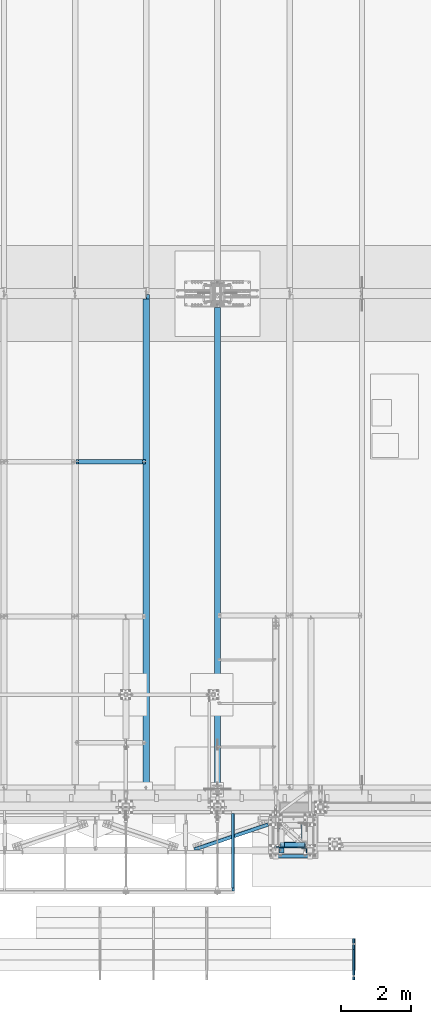
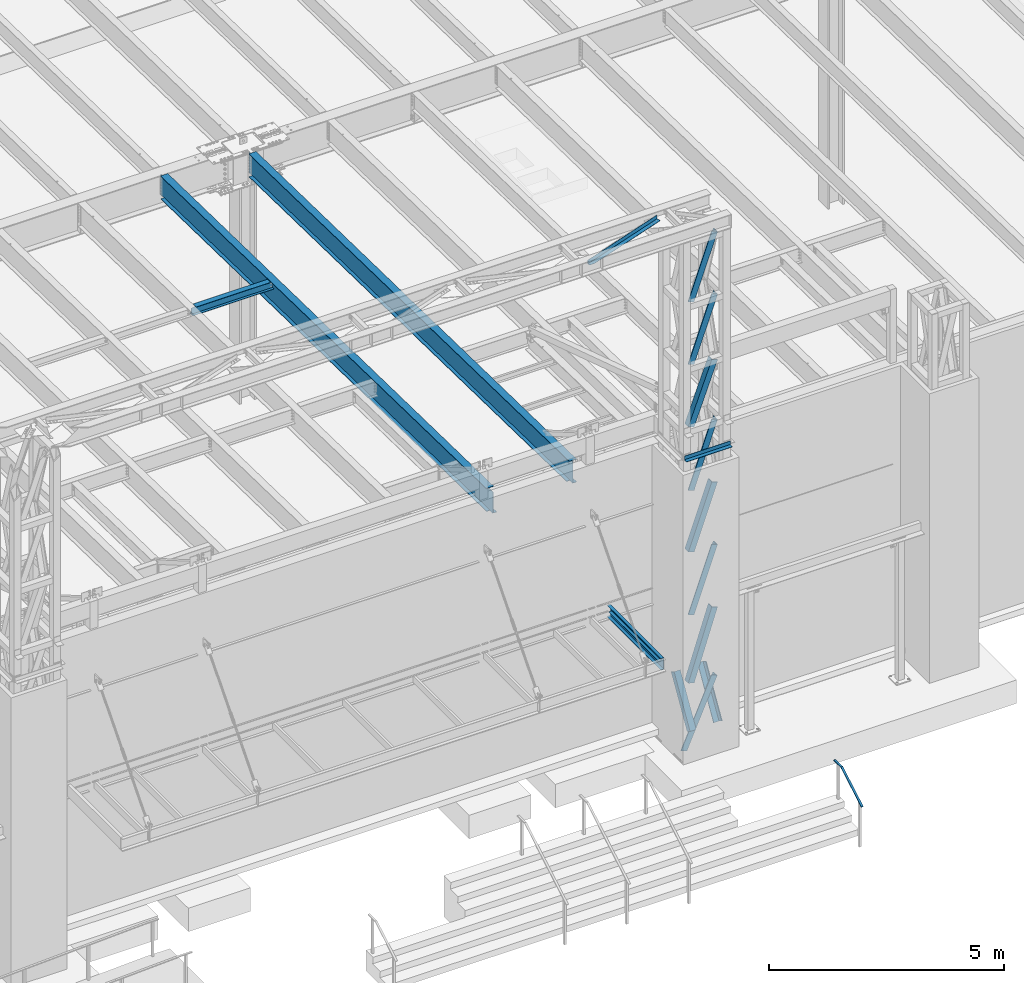
# One storey, part 1061 of 1763: 10 members, 8 beams, 7 elements without a shape of their own.
"""IFC2X3 building model written with IfcOpenShell, lengths in millimetres."""

from ifc_helpers import new_model, si_unit, frame, origin_with_axes, place, context, subcontext, project, spatial, faceted_brep, material, type_object, element, aggregate, save


model = new_model("IFC2X3")

# Units and contexts
model_context = context("Model", 3, precision=1e-05, world=origin_with_axes())
body_context = subcontext(model_context, "Body", "Model", "MODEL_VIEW")
ifc_project = project(units=[si_unit("LENGTHUNIT", "METRE", prefix="MILLI"), si_unit("AREAUNIT", "SQUARE_METRE"), si_unit("VOLUMEUNIT", "CUBIC_METRE"), si_unit("MASSUNIT", "GRAM", prefix="KILO"), si_unit("TIMEUNIT", "SECOND"), si_unit("PLANEANGLEUNIT", "RADIAN"), si_unit("SOLIDANGLEUNIT", "STERADIAN"), si_unit("THERMODYNAMICTEMPERATUREUNIT", "DEGREE_CELSIUS"), si_unit("LUMINOUSINTENSITYUNIT", "LUMEN")], contexts=[model_context])

# Site, building, storey
site_placement = place(None, origin_with_axes())
site = spatial("IfcSite", under=ifc_project, at=site_placement, CompositionType="ELEMENT")
building_placement = place(site_placement, origin_with_axes())
building = spatial("IfcBuilding", under=site, at=building_placement, Name="Undefined", CompositionType="ELEMENT")
storey_placement = place(building_placement, origin_with_axes())
storey = spatial("IfcBuildingStorey", under=building, at=storey_placement, Name="Undefined", CompositionType="ELEMENT", Elevation=0.0)

# Assembly, beam
assembly_1_placement = place(storey_placement, origin_with_axes())
assembly_1 = element("IfcElementAssembly", 1, at=assembly_1_placement, inside=storey, Name="BEAM", AssemblyPlace="NOTDEFINED", PredefinedType="RIGID_FRAME")
ifc_material_1 = material(Name="STEEL/A992")
beam_type_1 = type_object("IfcBeamType", Name="W8X18", PredefinedType="NOTDEFINED")
beam_1_placement = place(assembly_1_placement, frame((-53466.4372736983, -4344.55643304548, 11905.5938232069), z_axis=(0.0, 0.0, 1.0), x_axis=(1.0, 0.0, 0.0)))
beam_1 = element("IfcBeam", 2, at=beam_1_placement, type_object=beam_type_1, material=ifc_material_1, Name="BEAM", ObjectType="W8X18", context=body_context, shape_type="Brep", body=[
    faceted_brep([(87.3125001907247, -3.17500000000018, 64.8275016680727), (87.3125001907247, 3.17500000000018, 64.8275016680727), (17.4624999999905, 3.17500000000018, 64.8275016680727), (17.4624999999905, -3.17500000000018, 64.8275016680727), (92.1725797087711, -3.17500000000018, 65.7942315906603), (92.1725797087711, 3.17500000000018, 65.7942315906603), (96.2927561769247, -3.17500000000018, 68.5472454911378), (96.2927561769247, 3.17500000000018, 68.5472454911378), (97.1527139098253, -3.17500000000018, 69.8342631898486), (97.1527139098253, 3.17500000000018, 69.8342631898486), (17.4624999999905, -3.17500000000018, -95.25), (17.4624999999905, -66.6750000000002, -95.25), (2014.53750000001, -66.6750000000002, -95.25), (2014.53750000001, -3.17500000000018, -95.25), (17.4624999999905, -66.6750000000002, -103.1875), (2014.53750000001, -66.6750000000002, -103.1875), (17.4624999999905, 66.6750000000002, -103.1875), (2014.53750000001, 66.6750000000002, -103.1875), (17.4624999999905, 66.6750000000002, -95.25), (2014.53750000001, 66.6750000000002, -95.25), (17.4624999999905, 3.17500000000018, -95.25), (2014.53750000001, 3.17500000000018, -95.25), (2014.53750000001, 3.17500000000018, 64.8275016741045), (2014.53750000001, -3.17500000000018, 64.8275016741045), (1944.68749980927, 3.17500000000018, 64.8275016741045), (1944.68749980927, -3.17500000000018, 64.8275016741045), (1939.82742029122, 3.17500000000018, 65.794231596692), (1939.82742029122, -3.17500000000018, 65.794231596692), (1935.70724382307, 3.17500000000018, 68.5472454971696), (1935.70724382307, -3.17500000000018, 68.5472454971696), (1934.84728609776, 3.17500000000018, 69.8342631845208), (1934.84728609776, -3.17500000000018, 69.8342631845208), (1934.11974687481, 3.17500000000018, 70.3203893515383), (1934.11974687481, -3.17500000000018, 70.3203893515383), (1931.36673297434, 3.17500000000018, 74.440565819692), (1931.36673297434, -3.17500000000018, 74.440565819692), (1930.40000305175, 3.17500000000018, 79.3006453377384), (1930.40000305175, -3.17500000000018, 79.3006453377384), (101.599996948244, 3.17500000000018, 95.25), (101.599996948244, 66.6750000000002, 95.25), (1930.40000305175, 66.6750000000002, 95.25), (1930.40000305175, 3.17500000000018, 95.25), (101.599996948244, -66.6750000000002, 103.1875), (101.599996948244, -66.6750000000002, 95.25), (1930.40000305175, -66.6750000000002, 95.25), (1930.40000305175, -66.6750000000002, 103.1875), (101.599996948244, 66.6750000000002, 103.1875), (1930.40000305175, 66.6750000000002, 103.1875), (1930.40000305175, -3.17500000000018, 95.25), (101.599996948244, -3.17500000000018, 95.25), (101.599996948244, 3.17500000000018, 79.3006453379949), (101.599996948244, -3.17500000000018, 79.3006453379949), (100.633267025656, 3.17500000000018, 74.4405658199485), (100.633267025656, -3.17500000000018, 74.4405658199485), (97.8802531251786, 3.17500000000018, 70.3203893517948), (97.8802531251786, -3.17500000000018, 70.3203893517948)], [[[0, 1, 2, 3]], [[4, 5, 1, 0]], [[6, 7, 5, 4]], [[8, 9, 7, 6]], [[10, 11, 12, 13]], [[11, 14, 15, 12]], [[14, 16, 17, 15]], [[16, 18, 19, 17]], [[18, 20, 21, 19]], [[13, 12, 15, 17, 19, 21, 22, 23]], [[23, 22, 24, 25]], [[25, 24, 26, 27]], [[27, 26, 28, 29]], [[29, 28, 30, 31]], [[32, 33, 31, 30]], [[33, 32, 34, 35]], [[35, 34, 36, 37]], [[38, 39, 40, 41]], [[42, 43, 44, 45]], [[46, 42, 45, 47]], [[39, 46, 47, 40]], [[45, 44, 48, 37, 36, 41, 40, 47]], [[43, 49, 48, 44]], [[42, 46, 39, 38, 50, 51, 49, 43]], [[51, 50, 52, 53]], [[53, 52, 54, 55]], [[4, 0, 3, 10, 13, 23, 25, 27, 29, 31, 33, 35, 37, 48, 49, 51, 53, 55, 8, 6]], [[20, 18, 16, 14, 11, 10, 3, 2]], [[54, 52, 50, 38, 41, 36, 34, 32, 30, 28, 26, 24, 22, 21, 20, 2, 1, 5, 7, 9]], [[55, 54, 9, 8]]]),
])
aggregate(assembly_1, [beam_1])

# Assembly, members
assembly_2_placement = place(storey_placement, origin_with_axes())
assembly_2 = element("IfcElementAssembly", 3, at=assembly_2_placement, inside=storey, Name="FRAME", AssemblyPlace="NOTDEFINED", PredefinedType="RIGID_FRAME")
ifc_material_2 = material(Name="STEEL/A36")
member_type = type_object("IfcMemberType", Name="L6X6X7/8", PredefinedType="NOTDEFINED")
member_1_placement = place(assembly_2_placement, frame((-46925.9272043448, -15452.7272077239, 5676.9), z_axis=(-1.0, 0.0, 0.0), x_axis=(0.0, 0.513027731048337, 0.858372033080875)))
member_1 = element("IfcMember", 4, at=member_1_placement, type_object=member_type, material=ifc_material_2, Name="V. BRACE", ObjectType="L6X6X7/8", context=body_context, shape_type="Brep", body=[
    faceted_brep([(9.09494701772928e-13, 76.2000000000007, -76.2000000000844), (0.0, 76.2000000000007, 76.2000000000771), (1326.04215441225, 76.2000000009157, 76.1999999999971), (1326.04215441225, 76.2000000009157, -76.1999999999971), (0.0, 53.9750000000004, 76.2000000000771), (1326.04215441225, 53.9750000009208, 76.1999999999971), (1.81898940354586e-12, 53.9750000000004, -53.9750000000604), (1326.04215441225, 53.9750000009208, -53.9749999999985), (1.81898940354586e-12, -76.2000000000007, -53.9750000000604), (1326.04215441224, -76.199999999053, -53.9749999999985), (9.09494701772928e-13, -76.2000000000007, -76.2000000000844), (1326.04215441224, -76.199999999053, -76.1999999999971)], [[[0, 1, 2, 3]], [[1, 4, 5, 2]], [[4, 6, 7, 5]], [[6, 8, 9, 7]], [[8, 10, 11, 9]], [[10, 0, 3, 11]], [[5, 7, 9, 11, 3, 2]], [[10, 8, 6, 4, 1, 0]]]),
])
member_2_placement = place(assembly_2_placement, frame((-47570.4519986869, -15452.7272094253, 5676.9), z_axis=(1.0, 0.0, 0.0), x_axis=(0.0, 0.513027731048337, 0.858372033080875)))
member_2 = element("IfcMember", 5, at=member_2_placement, type_object=member_type, material=ifc_material_2, Name="V. BRACE", ObjectType="L6X6X7/8", context=body_context, shape_type="Brep", body=[
    faceted_brep([(9.09494701772928e-13, 76.2000000000007, -76.2000000000844), (0.0, 76.2000000000007, 76.2000000000771), (1326.04215441225, 76.2000000009157, 76.1999999999971), (1326.04215441225, 76.2000000009157, -76.1999999999971), (0.0, 53.9750000000004, 76.2000000000771), (1326.04215441225, 53.9750000009208, 76.1999999999971), (1.81898940354586e-12, 53.9750000000004, -53.9750000000604), (1326.04215441225, 53.9750000009208, -53.9749999999985), (1.81898940354586e-12, -76.2000000000007, -53.9750000000604), (1326.04215441224, -76.199999999053, -53.9749999999985), (9.09494701772928e-13, -76.2000000000007, -76.2000000000844), (1326.04215441224, -76.199999999053, -76.1999999999971)], [[[0, 1, 2, 3]], [[1, 4, 5, 2]], [[4, 6, 7, 5]], [[6, 8, 9, 7]], [[8, 10, 11, 9]], [[10, 0, 3, 11]], [[5, 7, 9, 11, 3, 2]], [[10, 8, 6, 4, 1, 0]]]),
])
member_3_placement = place(assembly_2_placement, frame((-47735.5524005648, -15287.6289235524, 5067.3), z_axis=(0.0, 1.0, 0.0), x_axis=(0.400955294202786, 1.00000025355767e-09, 0.916097621463323)))
member_3 = element("IfcMember", 6, at=member_3_placement, type_object=member_type, material=ifc_material_2, Name="V. BRACE", ObjectType="L6X6X7/8", context=body_context, shape_type="Brep", body=[
    faceted_brep([(74.9404777348027, 76.199999999888, -76.2000000000044), (74.9404778871212, 76.1999999996915, 76.1999999999953), (1940.84119258349, 76.2000000036787, 76.1999999991021), (1940.84119258334, 76.2000000038752, -76.2000000008975), (74.9404778871649, 53.9749999997148, 76.200000000008), (1940.84119258348, 53.9750000036947, 76.1999999991149), (74.9404777570599, 53.9749999998676, -53.9749999999931), (1940.84119258335, 53.9750000038621, -53.9750000008862), (74.9404777573181, -76.2000000000189, -53.9749999999312), (1940.84119258335, -76.199999996039, -53.9750000008244), (74.9404777351083, -76.1999999999971, -76.1999999999316), (1940.84119258333, -76.1999999960099, -76.2000000008247)], [[[0, 1, 2, 3]], [[1, 4, 5, 2]], [[4, 6, 7, 5]], [[6, 8, 9, 7]], [[8, 10, 11, 9]], [[10, 0, 3, 11]], [[5, 7, 9, 11, 3, 2]], [[10, 8, 6, 4, 1, 0]]]),
])
member_4_placement = place(assembly_2_placement, frame((-47537.345968225, -15300.3289245429, 16748.720313), z_axis=(-5.63699999961987e-06, 0.999999999984112, 0.0), x_axis=(0.335283282133074, 2.03400000119903e-06, 0.942117360373927)))
member_4 = element("IfcMember", 7, at=member_4_placement, type_object=member_type, material=ifc_material_2, Name="V. BRACE", ObjectType="L6X6X7/8", context=body_context, shape_type="Brep", body=[
    faceted_brep([(9.09494701772928e-13, 76.2000000000007, -76.2000000000844), (0.0, 76.2000000000007, 76.2000000000771), (1724.84329343789, 76.1999999996478, 76.2000000010958), (1724.84329343754, 76.2000000000044, -76.1999999989348), (0.0, 53.9750000000004, 76.2000000000771), (1724.84329343786, 53.9749999996711, 76.2000000010812), (1.81898940354586e-12, 53.9750000000004, -53.9750000000604), (1724.84329343756, 53.9749999999767, -53.9749999989453), (1.81898940354586e-12, -76.2000000000007, -53.9750000000604), (1724.84329343738, -76.1999999998734, -53.9749999990436), (9.09494701772928e-13, -76.2000000000007, -76.2000000000844), (1724.84329343733, -76.1999999998225, -76.1999999990512)], [[[0, 1, 2, 3]], [[1, 4, 5, 2]], [[4, 6, 7, 5]], [[6, 8, 9, 7]], [[8, 10, 11, 9]], [[10, 0, 3, 11]], [[5, 7, 9, 11, 3, 2]], [[10, 8, 6, 4, 1, 0]]]),
])
member_5_placement = place(assembly_2_placement, frame((-47537.1147044168, -15300.3289245429, 15123.7156239956), z_axis=(0.0, 1.0, 0.0), x_axis=(0.334874224906127, 9.99999833869425e-10, 0.942262836735866)))
member_5 = element("IfcMember", 8, at=member_5_placement, type_object=member_type, material=ifc_material_2, Name="V. BRACE", ObjectType="L6X6X7/8", context=body_context, shape_type="Brep", body=[
    faceted_brep([(9.09494701772928e-13, 76.2000000000007, -76.2000000000844), (0.0, 76.2000000000007, 76.2000000000771), (1724.57686399414, 76.1999999983163, 76.1999999992258), (1724.57686399422, 76.1999999981927, -76.2000000007738), (0.0, 53.9750000000004, 76.2000000000771), (1724.57686399418, 53.974999998245, 76.1999999992295), (1.81898940354586e-12, 53.9750000000004, -53.9750000000604), (1724.57686399425, 53.9749999981432, -53.9750000007716), (1.81898940354586e-12, -76.2000000000007, -53.9750000000604), (1724.57686399449, -76.2000000022381, -53.9750000007571), (9.09494701772928e-13, -76.2000000000007, -76.2000000000844), (1724.5768639945, -76.2000000022599, -76.2000000007574)], [[[0, 1, 2, 3]], [[1, 4, 5, 2]], [[4, 6, 7, 5]], [[6, 8, 9, 7]], [[8, 10, 11, 9]], [[10, 0, 3, 11]], [[5, 7, 9, 11, 3, 2]], [[10, 8, 6, 4, 1, 0]]]),
])
member_6_placement = place(assembly_2_placement, frame((-47537.7850007047, -15300.3289245429, 13498.7109359956), z_axis=(0.936796284108881, 3.99999953515362e-09, -0.349875295040665), x_axis=(0.349875295040666, 9.99999999198703e-10, 0.936796284108881)))
member_6 = element("IfcMember", 9, at=member_6_placement, type_object=member_type, material=ifc_material_2, Name="V. BRACE", ObjectType="L6X6X7/8", context=body_context, shape_type="Brep", body=[
    faceted_brep([(9.09494701772928e-13, 76.2000000000007, -76.2000000000844), (0.0, 76.2000000000007, 76.2000000000771), (1655.20577994027, 76.2000000011249, 76.1999999992604), (1655.20577994016, 76.2000000016196, -76.2000000007392), (0.0, 53.9750000000004, 76.2000000000771), (1655.20577994026, 53.9750000011918, 76.1999999992622), (1.81898940354586e-12, 53.9750000000004, -53.9750000000604), (1655.20577994017, 53.9750000016065, -53.9750000007371), (1.81898940354586e-12, -76.2000000000007, -53.9750000000604), (1655.20577994013, -76.199999998018, -53.975000000728), (9.09494701772928e-13, -76.2000000000007, -76.2000000000844), (1655.2057799401, -76.199999997938, -76.2000000007283)], [[[0, 1, 2, 3]], [[1, 4, 5, 2]], [[4, 6, 7, 5]], [[6, 8, 9, 7]], [[8, 10, 11, 9]], [[10, 0, 3, 11]], [[5, 7, 9, 11, 3, 2]], [[10, 8, 6, 4, 1, 0]]]),
])
member_7_placement = place(assembly_2_placement, frame((-47536.9219951421, -15300.3289245429, 11849.0999999956), z_axis=(0.0, 1.0, 0.0), x_axis=(0.330549340153199, 9.99999554506466e-10, 0.943788712437421)))
member_7 = element("IfcMember", 10, at=member_7_placement, type_object=member_type, material=ifc_material_2, Name="V. BRACE", ObjectType="L6X6X7/8", context=body_context, shape_type="Brep", body=[
    faceted_brep([(9.09494701772928e-13, 76.2000000000007, -76.2000000000844), (0.0, 76.2000000000007, 76.2000000000771), (1747.86042051722, 76.1999999938562, 76.199999999164), (1747.86042051722, 76.1999999937107, -76.2000000008356), (0.0, 53.9750000000004, 76.2000000000771), (1747.86042051722, 53.9749999938722, 76.1999999991804), (1.81898940354586e-12, 53.9750000000004, -53.9750000000604), (1747.86042051722, 53.9749999937558, -53.9750000008189), (1.81898940354586e-12, -76.2000000000007, -53.9750000000604), (1747.86042051721, -76.2000000061671, -53.9750000007189), (9.09494701772928e-13, -76.2000000000007, -76.2000000000844), (1747.86042051721, -76.2000000061889, -76.2000000007192)], [[[0, 1, 2, 3]], [[1, 4, 5, 2]], [[4, 6, 7, 5]], [[6, 8, 9, 7]], [[8, 10, 11, 9]], [[10, 0, 3, 11]], [[5, 7, 9, 11, 3, 2]], [[10, 8, 6, 4, 1, 0]]]),
])
member_8_placement = place(assembly_2_placement, frame((-47536.4531690055, -15300.3289245429, 10248.701776542), z_axis=(0.942338290337835, 3.99999953515361e-09, -0.334661839119978), x_axis=(0.33466183911998, 9.99999794265608e-10, 0.942338290337834)))
member_8 = element("IfcMember", 11, at=member_8_placement, type_object=member_type, material=ifc_material_2, Name="V. BRACE", ObjectType="L6X6X7/8", context=body_context, shape_type="Brep", body=[
    faceted_brep([(9.09494701772928e-13, 76.2000000000007, -76.2000000000844), (0.0, 76.2000000000007, 76.2000000000771), (1724.4605169534, 76.1999999968903, 76.199999999204), (1724.46051695335, 76.1999999966574, -76.2000000007956), (0.0, 53.9750000000004, 76.2000000000771), (1724.46051695341, 53.9749999968262, 76.1999999992131), (1.81898940354586e-12, 53.9750000000004, -53.9750000000604), (1724.46051695337, 53.9749999966371, -53.975000000788), (1.81898940354586e-12, -76.2000000000007, -53.9750000000604), (1724.46051695341, -76.2000000037297, -53.9750000007334), (9.09494701772928e-13, -76.2000000000007, -76.2000000000844), (1724.4605169534, -76.2000000037588, -76.2000000007338)], [[[0, 1, 2, 3]], [[1, 4, 5, 2]], [[4, 6, 7, 5]], [[6, 8, 9, 7]], [[8, 10, 11, 9]], [[10, 0, 3, 11]], [[5, 7, 9, 11, 3, 2]], [[10, 8, 6, 4, 1, 0]]]),
])
member_9_placement = place(assembly_2_placement, frame((-47537.0341335539, -15300.3289245429, 8623.3), z_axis=(0.0, 1.0, 0.0), x_axis=(0.334512951060313, 1.00000043783993e-09, 0.942391153169914)))
member_9 = element("IfcMember", 12, at=member_9_placement, type_object=member_type, material=ifc_material_2, Name="V. BRACE", ObjectType="L6X6X7/8", context=body_context, shape_type="Brep", body=[
    faceted_brep([(9.09494701772928e-13, 76.2000000000007, -76.2000000000844), (0.0, 76.2000000000007, 76.2000000000771), (1724.76317823229, 76.1999999951586, 76.1999999991876), (1724.76317823233, 76.199999994933, -76.200000000812), (0.0, 53.9750000000004, 76.2000000000771), (1724.7631782323, 53.97499999516, 76.1999999992004), (1.81898940354586e-12, 53.9750000000004, -53.9750000000604), (1724.76317823234, 53.9749999949636, -53.9750000007989), (1.81898940354586e-12, -76.2000000000007, -53.9750000000604), (1724.76317823241, -76.2000000050757, -53.975000000717), (9.09494701772928e-13, -76.2000000000007, -76.2000000000844), (1724.76317823241, -76.2000000050975, -76.2000000007174)], [[[0, 1, 2, 3]], [[1, 4, 5, 2]], [[4, 6, 7, 5]], [[6, 8, 9, 7]], [[8, 10, 11, 9]], [[10, 0, 3, 11]], [[5, 7, 9, 11, 3, 2]], [[10, 8, 6, 4, 1, 0]]]),
])
member_10_placement = place(assembly_2_placement, frame((-47536.3195303895, -15300.3289245429, 6845.30021654201), z_axis=(0.951343767819845, 3.99999953515362e-09, -0.30813152294165), x_axis=(0.308131522941648, 1.00000004810686e-09, 0.951343767819846)))
member_10 = element("IfcMember", 13, at=member_10_placement, type_object=member_type, material=ifc_material_2, Name="V. BRACE", ObjectType="L6X6X7/8", context=body_context, shape_type="Brep", body=[
    faceted_brep([(9.09494701772928e-13, 76.2000000000007, -76.2000000000844), (0.0, 76.2000000000007, 76.2000000000771), (1868.93512461962, 76.199999997596, 76.1999999991676), (1868.93512461956, 76.1999999976761, -76.2000000008338), (0.0, 53.9750000000004, 76.2000000000771), (1868.9351246196, 53.9749999976411, 76.1999999991676), (1.81898940354586e-12, 53.9750000000004, -53.9750000000604), (1868.93512461955, 53.9749999977066, -53.9750000008316), (1.81898940354586e-12, -76.2000000000007, -53.9750000000604), (1868.93512461943, -76.2000000020707, -53.975000000828), (9.09494701772928e-13, -76.2000000000007, -76.2000000000844), (1868.93512461942, -76.2000000020489, -76.2000000008265)], [[[0, 1, 2, 3]], [[1, 4, 5, 2]], [[4, 6, 7, 5]], [[6, 8, 9, 7]], [[8, 10, 11, 9]], [[10, 0, 3, 11]], [[5, 7, 9, 11, 3, 2]], [[10, 8, 6, 4, 1, 0]]]),
])

# Assembly, beam
assembly_3_placement = place(storey_placement, origin_with_axes())
assembly_3 = element("IfcElementAssembly", 14, at=assembly_3_placement, inside=storey, Name="BEAM", AssemblyPlace="NOTDEFINED", PredefinedType="RIGID_FRAME")
beam_type_2 = type_object("IfcBeamType", Name="C12X20.7", PredefinedType="NOTDEFINED")
beam_2_placement = place(assembly_3_placement, frame((-48951.7754463109, -16605.2525869861, 8585.2), z_axis=(0.0, 0.0, -1.0), x_axis=(0.0, 1.0, 0.0)))
beam_2 = element("IfcBeam", 15, at=beam_2_placement, type_object=beam_type_2, material=ifc_material_2, Name="BEAM", ObjectType="C12X20.7", context=body_context, shape_type="Brep", body=[
    faceted_brep([(0.0, 38.1000000000004, -152.4), (0.0, 38.1000000000004, 152.4), (2295.52500000448, 38.0999999999985, 152.4), (2295.52500000448, 38.0999999999985, -152.4), (0.0, -38.1000000000004, 152.4), (2295.52500000448, -38.0999999999985, 152.4), (0.0, -38.1000000000004, 146.04746), (2295.52500000448, -38.0999999999985, 146.04746), (0.0, 30.1625000000004, 134.6749275), (2295.52500000448, 30.1624999999985, 134.6749275), (0.0, 30.1625000000004, -134.6749275), (2295.52500000448, 30.1624999999985, -134.6749275), (0.0, -38.1000000000004, -146.04746), (2295.52500000448, -38.0999999999985, -146.04746), (0.0, -38.1000000000004, -152.4), (2295.52500000448, -38.0999999999985, -152.4)], [[[0, 1, 2, 3]], [[1, 4, 5, 2]], [[4, 6, 7, 5]], [[6, 8, 9, 7]], [[8, 10, 11, 9]], [[10, 12, 13, 11]], [[12, 14, 15, 13]], [[14, 0, 3, 15]], [[5, 7, 9, 11, 13, 15, 3, 2]], [[14, 12, 10, 8, 6, 4, 1, 0]]]),
])

assembly_4_placement = place(storey_placement, origin_with_axes())
assembly_4 = element("IfcElementAssembly", 16, at=assembly_4_placement, inside=storey, Name="ANGLE", AssemblyPlace="NOTDEFINED", PredefinedType="RIGID_FRAME")
beam_type_3 = type_object("IfcBeamType", Name="L4X4X1/4", PredefinedType="NOTDEFINED")
beam_3_placement = place(assembly_4_placement, frame((-47719.2631087062, -14627.7197764565, 18672.175), z_axis=(0.320655215158338, -0.947195984467713, 0.0), x_axis=(-0.947195984467714, -0.320655215158336, 0.0)))
beam_3 = element("IfcBeam", 17, at=beam_3_placement, type_object=beam_type_3, material=ifc_material_2, Name="ANGLE", ObjectType="L4X4X1/4", context=body_context, shape_type="Brep", body=[
    faceted_brep([(2474.08815029644, 44.4500000000007, -44.4499999984348), (2474.08815029644, -50.7999999999993, -44.4499999984348), (2474.08778122983, -50.7999999999993, -50.7999999984352), (2474.08778122983, 50.7999999999993, -50.7999999984352), (2474.09159971638, 50.7999999999993, 15.0236743646817), (2474.09159971638, 44.4500000000007, 15.0236743646817), (2368.45312543344, 50.7999999999993, 50.8000000014833), (2368.45312543344, 44.4500000000007, 50.8000000014833), (248.928076724376, 44.4500000000007, 50.8000000001518), (248.921250277446, 44.4500000000007, -44.4499999998336), (248.921250277446, -50.7999999999993, -44.4499999998336), (248.920795180988, -50.7999999999993, -50.7999999998303), (248.920795180988, 50.7999999999993, -50.7999999998303), (248.928076724376, 50.7999999999993, 50.8000000001518)], [[[0, 1, 2, 3, 4, 5]], [[5, 4, 6, 7]], [[0, 5, 7, 8, 9]], [[1, 0, 9, 10]], [[2, 1, 10, 11]], [[3, 2, 11, 12]], [[6, 4, 3, 12, 13]], [[7, 6, 13, 8]], [[12, 11, 10, 9, 8, 13]]]),
])
aggregate(assembly_4, [beam_3])

# Beam
beam_type_4 = type_object("IfcBeamType", Name="L4X4X3/8", PredefinedType="NOTDEFINED")
beam_4_placement = place(assembly_2_placement, frame((-46684.6272044142, -15608.3022094127, 12903.2), z_axis=(0.0, -1.0, 0.0), x_axis=(-1.0, 0.0, 0.0)))
beam_4 = element("IfcBeam", 18, at=beam_4_placement, type_object=beam_type_4, material=ifc_material_2, Name="ANGLE", ObjectType="L4X4X3/8", context=body_context, shape_type="Brep", body=[
    faceted_brep([(-3.63797880709171e-11, 50.8000000000011, -50.8000000000538), (-1.96450855582952e-10, 50.8000000000393, 50.7999999999374), (1127.1251953125, 50.7999999999993, 50.7999999999993), (1127.1251953125, 50.7999999999993, -50.7999999999993), (0.0, 41.2749999999996, 50.7999999999993), (1127.1251953125, 41.2749999999996, 50.7999999999993), (0.0, 41.2749999999996, -41.2750000000015), (1127.1251953125, 41.2749999999996, -41.2749999999996), (0.0, -50.7999999999993, -41.2750000000015), (1127.1251953125, -50.7999999999993, -41.2749999999996), (2.11002770811319e-10, -50.8000000000357, -50.799999999952), (1127.1251953125, -50.7999999999993, -50.7999999999993)], [[[0, 1, 2, 3]], [[1, 4, 5, 2]], [[4, 6, 7, 5]], [[6, 8, 9, 7]], [[8, 10, 11, 9]], [[10, 0, 3, 11]], [[5, 7, 9, 11, 3, 2]], [[10, 8, 6, 4, 1, 0]]]),
])

aggregate(assembly_2, [member_1, member_2, member_3, member_4, member_5, member_6, member_7, member_8, member_9, member_10, beam_4])

beam_type_5 = type_object("IfcBeamType", Name="L3X3X1/4", PredefinedType="NOTDEFINED")
beam_5_placement = place(assembly_3_placement, frame((-48959.6477739724, -16516.3525865753, 8648.7), z_axis=(-1.0, 0.0, 0.0), x_axis=(0.0, 1.0, 0.0)))
beam_5 = element("IfcBeam", 19, at=beam_5_placement, type_object=beam_type_5, material=ifc_material_2, Name="ANGLE", ObjectType="L3X3X1/4", context=body_context, shape_type="Brep", body=[
    faceted_brep([(0.0, 38.0999999999985, -38.1000000000004), (0.0, 38.0999999999985, 38.1000000000004), (2117.72497269498, 38.1000000000004, 38.0999999992346), (2117.72497269495, 38.1000000000004, -38.1000000007625), (0.0, 31.75, 38.1000000000058), (2117.72497269498, 31.75, 38.0999999992346), (0.0, 31.75, -31.75), (2117.72497269495, 31.75, -31.750000000764), (0.0, -38.1000000000004, -31.75), (2117.72497269495, -38.1000000000004, -31.750000000764), (0.0, -38.0999999999985, -38.1000000000004), (2117.72497269495, -38.1000000000004, -38.1000000007625)], [[[0, 1, 2, 3]], [[1, 4, 5, 2]], [[4, 6, 7, 5]], [[6, 8, 9, 7]], [[8, 10, 11, 9]], [[10, 0, 3, 11]], [[5, 7, 9, 11, 3, 2]], [[10, 8, 6, 4, 1, 0]]]),
])

aggregate(assembly_3, [beam_5, beam_2])

# Assembly, beam
assembly_5_placement = place(storey_placement, origin_with_axes())
assembly_5 = element("IfcElementAssembly", 20, at=assembly_5_placement, inside=storey, Name="HANDRAIL", AssemblyPlace="NOTDEFINED", PredefinedType="RIGID_FRAME")
beam_type_6 = type_object("IfcBeamType", PredefinedType="NOTDEFINED")
beam_6_placement = place(assembly_5_placement, frame((-45509.8872736984, -19143.8249179603, 5206.50837891029), z_axis=(-1.0, 0.0, 0.0), x_axis=(0.0, 0.863778900717086, 0.503871025834967)))
beam_6 = element("IfcBeam", 21, at=beam_6_placement, type_object=beam_type_6, material=ifc_material_2, Name="HANDRAIL", context=body_context, shape_type="Brep", body=[
    faceted_brep([(2.91038304567337e-11, -9.52499999999418, -25.4000000000015), (2.91038304567337e-11, -9.52499999999418, 25.4000000000015), (-5.82076609134674e-11, 9.52499999999418, 25.4000000000015), (-5.82076609134674e-11, 9.52499999999418, -25.4000000000015), (1006.59513807963, 9.52500455970767, 25.4000000000015), (1006.59513807963, 9.52500455970767, -25.4000000000015), (1011.74528904162, -9.52499541697944, -25.4000000000015), (1011.74528904162, -9.52499541697944, 25.4000000000015), (1267.65059126487, 161.807344696828, 25.4000000000015), (1267.65059126487, 161.807344696828, -25.4000000000015), (1277.2493339458, 145.352356427451, 25.4000000000015), (1277.2493339458, 145.352356427451, -25.4000000000015)], [[[0, 1, 2, 3]], [[3, 2, 4, 5]], [[1, 0, 6, 7]], [[5, 4, 8, 9]], [[4, 2, 1, 7, 10, 8]], [[7, 6, 11, 10]], [[6, 0, 3, 5, 9, 11]], [[10, 11, 9, 8]]]),
])
aggregate(assembly_5, [beam_6])

assembly_6_placement = place(storey_placement, origin_with_axes())
assembly_6 = element("IfcElementAssembly", 22, at=assembly_6_placement, inside=storey, Name="BEAM", AssemblyPlace="NOTDEFINED", PredefinedType="RIGID_FRAME")
beam_type_7 = type_object("IfcBeamType", Name="W24X55", PredefinedType="NOTDEFINED")
beam_7_placement = place(assembly_6_placement, frame((-49402.4372736983, -13722.2711313756, 11904.7280453544), z_axis=(0.0, 0.0209013539966291, 0.999781542838788), x_axis=(0.0, 0.999781542776098, -0.0209013569953182)))
beam_7 = element("IfcBeam", 23, at=beam_7_placement, type_object=beam_type_7, material=ifc_material_1, Name="BEAM", ObjectType="W24X55", context=body_context, shape_type="Brep", body=[
    faceted_brep([(13780.8772902288, 5.06261017802171, -287.337500004773), (13780.8772902291, 5.06238689222664, -300.037500004782), (13780.8771990977, 88.9000000000015, -300.037500004782), (13780.8771990977, 88.9000000000015, -287.337500004774), (13939.550013095, 5.06255936930393, -300.037500004835), (13939.2845079612, 5.06278236646904, -287.337500004824), (139.995971125729, 4.76249999999709, 287.337500000185), (139.995971125729, 88.9000000000015, 287.337500000185), (13780.877454334, 88.9000000000015, 287.337499995687), (13780.877454334, 4.76249999999709, 287.337499995687), (13939.2845079612, -4.76249999999709, -287.337500004824), (152.010082451758, -4.76249999999709, -287.337500000282), (152.010082451758, -88.9000000000015, -287.337500000282), (13780.8774488972, -88.9000000000015, -287.337500004773), (13780.8773577661, -5.06238681222749, -287.337500004773), (13939.2845079612, -5.06221462368558, -287.337500004824), (13788.7173746252, -4.76249999999709, 249.944231589652), (13784.597198157, -4.76249999999709, 252.697245490135), (13781.8441842566, -4.76249999999709, 256.817421958298), (13780.877454334, -4.76249999999709, 261.677501476357), (13780.877454334, -4.76249999999709, 287.337499995687), (139.995971125729, -4.76249999999709, 287.337500000185), (13928.0723515641, -4.76249999999709, 248.977501667061), (13793.5774541433, -4.76249999999709, 248.977501667059), (139.995971125729, -88.9000000000015, 287.337500000185), (13780.877454334, -88.9000000000015, 287.337499995687), (139.730465903054, -88.9000000000015, 300.037500000193), (13780.877454334, -88.9000000000015, 300.037499995698), (139.730465903054, 88.9000000000015, 300.037500000193), (13780.877454334, 88.9000000000015, 300.037499995698), (13780.877454334, 4.76249999999709, 261.677501476357), (13781.8441842566, 4.76249999999709, 256.817421958298), (13784.597198157, 4.76249999999709, 252.697245490135), (13788.7173746252, 4.76249999999709, 249.944231589652), (13793.5774541433, 4.76249999999709, 248.977501667059), (13928.0723515641, 4.76249999999709, 248.977501667061), (13939.2845079612, 4.76249999999709, -287.337500004824), (152.010082451758, 4.76249999999709, -287.337500000282), (273.003030659551, 88.9000000000015, -287.337500000322), (273.003030659549, 88.9000000000015, -300.037500000333), (273.003095549398, 5.06262327043805, -300.037500000333), (273.003095549591, 5.06237365042762, -287.337500000322), (152.275587674432, 5.06252982738806, -300.037500000291), (152.010082451758, 5.06228000190458, -287.337500000282), (152.275587674432, -88.9000000000015, -300.037500000291), (13780.8774488972, -88.9000000000015, -300.037500004784), (13780.8773577663, -5.06261009801528, -300.037500004784), (13939.550013095, -5.06243762085069, -300.037500004835)], [[[0, 1, 2, 3]], [[4, 1, 0, 5]], [[6, 7, 8, 9]], [[10, 11, 12, 13, 14, 15]], [[16, 17, 18, 19, 20, 21, 11, 10, 22, 23]], [[24, 21, 20, 25]], [[26, 24, 25, 27]], [[28, 26, 27, 29]], [[7, 28, 29, 8]], [[27, 25, 20, 19, 30, 9, 8, 29]], [[18, 31, 30, 19]], [[17, 32, 31, 18]], [[16, 33, 32, 17]], [[23, 34, 33, 16]], [[22, 35, 34, 23]], [[36, 37, 6, 9, 30, 31, 32, 33, 34, 35]], [[38, 39, 40, 41]], [[41, 40, 42, 43]], [[44, 12, 11, 21, 24, 26, 28, 7, 6, 37, 43, 42]], [[12, 44, 45, 13]], [[13, 45, 46, 14]], [[47, 15, 14, 46]], [[36, 35, 22, 10, 15, 47, 4, 5]], [[3, 38, 41, 43, 37, 36, 5, 0]], [[39, 38, 3, 2]], [[47, 46, 45, 44, 42, 40, 39, 2, 1, 4]]]),
])
aggregate(assembly_6, [beam_7])

assembly_7_placement = place(storey_placement, origin_with_axes())
assembly_7 = element("IfcElementAssembly", 24, at=assembly_7_placement, inside=storey, Name="BEAM", AssemblyPlace="NOTDEFINED", PredefinedType="RIGID_FRAME")
beam_8_placement = place(assembly_7_placement, frame((-51434.4372736983, -13722.2711313756, 11904.7280453544), z_axis=(0.0, 0.0209013539966291, 0.999781542838788), x_axis=(0.0, 0.999781542776098, -0.0209013569953182)))
beam_8 = element("IfcBeam", 25, at=beam_8_placement, type_object=beam_type_7, material=ifc_material_1, Name="BEAM", ObjectType="W24X55", context=body_context, shape_type="Brep", body=[
    faceted_brep([(14016.6713189086, 5.06262333965424, -287.337500004851), (14016.6713189087, 5.06237371335737, -300.037500004863), (14016.6713136267, 88.9000000000015, -300.037500004863), (14016.6713136267, 88.9000000000015, -287.337500004851), (14067.3716906706, 5.0625, -300.037500004877), (14067.1061854479, 5.0625, -287.337500004867), (140.42076922026, -4.76249999999709, 248.977501678848), (140.42076922026, 4.76249999999709, 248.977501678848), (20.9156645386702, 4.76249999999709, 248.977501678888), (20.9156645386702, -4.76249999999709, 248.977501678888), (145.280848738317, -4.76249999999709, 249.944231601437), (145.280848738317, 4.76249999999709, 249.944231601437), (149.401025206482, -4.76249999999709, 252.697245501922), (149.401025206482, 4.76249999999709, 252.697245501922), (152.15403910697, -4.76249999999709, 256.817421970085), (152.15403910697, 4.76249999999709, 256.817421970085), (153.12076902956, -4.76249999999709, 261.67750148814), (153.12076902956, 4.76249999999709, 261.67750148814), (153.120769029574, -88.9000000000015, 300.03750000019), (153.120769029574, 88.9000000000015, 300.03750000019), (153.120769029569, 88.9000000000015, 287.33750000018), (153.120769029569, 4.76249999999709, 287.33750000018), (153.120769029569, -4.76249999999709, 287.33750000018), (153.120769029569, -88.9000000000015, 287.33750000018), (14016.6713298856, 88.9000000000015, 287.33749999561), (14016.6713298856, 4.76249999999709, 287.33749999561), (14168.7283855234, 4.76249999999709, -287.3375000049), (32.1278246917773, 4.76249999999709, -287.337500000243), (14016.6713298856, 4.76249999999709, 255.327497550523), (14017.6380598082, 4.76249999999709, 250.467418032464), (14020.3910737087, 4.76249999999709, 246.347241564303), (14024.5112501769, 4.76249999999709, 243.594227663818), (14029.3713296949, 4.76249999999709, 242.627497741227), (14157.648978064, 4.76249999999709, 242.627497741229), (153.120588301108, 88.9000000000015, -287.337500000282), (153.120588301104, 88.9000000000015, -300.037500000293), (153.120599954549, 5.06262326912838, -300.037500000293), (153.120599954584, 5.06237364569824, -287.337500000282), (32.3933299144519, 5.06260648809985, -300.037500000253), (32.1278246917773, 5.06235682772967, -287.337500000243), (32.3933299144519, -88.9000000000015, -300.037500000253), (32.1278246917773, -88.9000000000015, -287.337500000243), (32.1278246917773, -4.76249999999709, -287.337500000243), (14168.9938907462, -88.9000000000015, -300.03750000491), (14168.7283855236, -88.9000000000015, -287.3375000049), (14168.7283855234, -4.76249999999709, -287.3375000049), (14024.5112501769, -4.76249999999709, 243.594227663818), (14020.3910737087, -4.76249999999709, 246.347241564303), (14017.6380598082, -4.76249999999709, 250.467418032464), (14016.6713298856, -4.76249999999709, 255.327497550523), (14016.6713298856, -4.76249999999709, 287.33749999561), (14157.648978064, -4.76249999999709, 242.627497741229), (14029.3713296949, -4.76249999999709, 242.627497741227), (14016.6713298856, -88.9000000000015, 287.33749999561), (14016.6713298856, -88.9000000000015, 300.03749999562), (14016.6713298856, 88.9000000000015, 300.03749999562), (14168.9938907729, 5.0625, -300.03750000491), (14168.7283855502, 5.0625, -287.3375000049)], [[[0, 1, 2, 3]], [[4, 1, 0, 5]], [[6, 7, 8, 9]], [[10, 11, 7, 6]], [[12, 13, 11, 10]], [[14, 15, 13, 12]], [[16, 17, 15, 14]], [[18, 19, 20, 21, 17, 16, 22, 23]], [[21, 20, 24, 25]], [[26, 27, 8, 7, 11, 13, 15, 17, 21, 25, 28, 29, 30, 31, 32, 33]], [[34, 35, 36, 37]], [[37, 36, 38, 39]], [[40, 41, 42, 9, 8, 27, 39, 38]], [[41, 40, 43, 44]], [[42, 41, 44, 45]], [[46, 47, 48, 49, 50, 22, 16, 14, 12, 10, 6, 9, 42, 45, 51, 52]], [[23, 22, 50, 53]], [[18, 23, 53, 54]], [[19, 18, 54, 55]], [[20, 19, 55, 24]], [[54, 53, 50, 49, 28, 25, 24, 55]], [[48, 29, 28, 49]], [[47, 30, 29, 48]], [[46, 31, 30, 47]], [[52, 32, 31, 46]], [[51, 33, 32, 52]], [[45, 44, 43, 56, 57, 26, 33, 51]], [[56, 4, 5, 57]], [[3, 34, 37, 39, 27, 26, 57, 5, 0]], [[35, 34, 3, 2]], [[56, 43, 40, 38, 36, 35, 2, 1, 4]]]),
])
aggregate(assembly_7, [beam_8])

save(model, "model.ifc")
